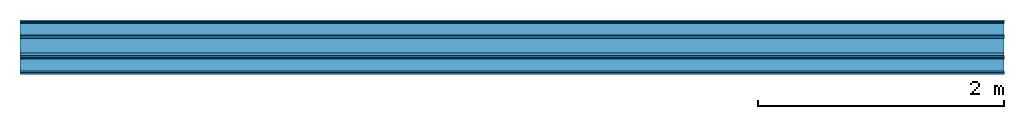
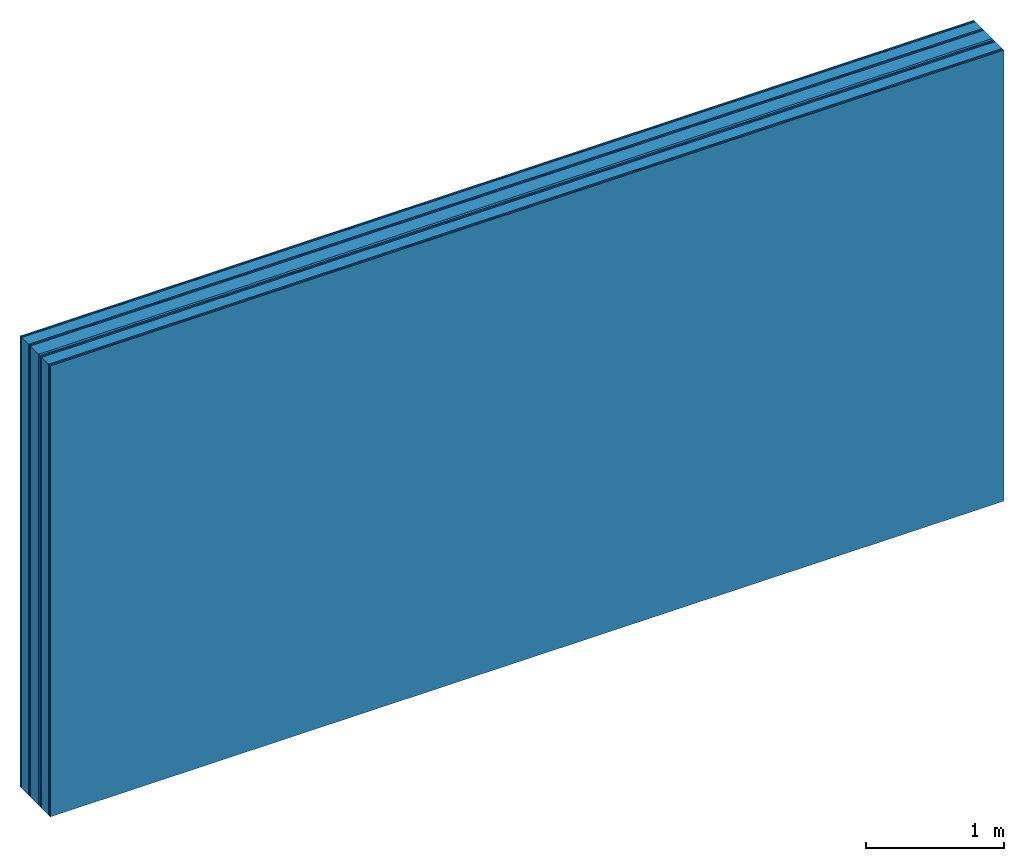
# One storey: 10 plates, 2 members, 1 element without a shape of its own.
"""IFC4 building model written with IfcOpenShell, lengths in metres."""

from ifc_helpers import new_model, si_unit, derived_unit, direction, frame, frame_2d, origin, origin_with_axes, place, context, project, spatial, rectangle, extrude, material, layer, layer_set, type_object, element, aggregate, save


model = new_model("IFC4")

# Units and contexts
plan_context = context("Plan", 3, precision=1e-05, world=origin(), true_north=direction((0.0, 1.0)))
model_context = context("Model", 3, precision=1e-05, world=origin(), true_north=direction((0.0, 1.0)))
ifc_project = project(units=[si_unit("LENGTHUNIT", "METRE"), derived_unit("SOUNDPRESSUREUNIT", [(si_unit("PRESSUREUNIT", "PASCAL", prefix="MICRO"), 0)]), si_unit("ENERGYUNIT", "JOULE", prefix="MEGA"), si_unit("MASSUNIT", "GRAM", prefix="KILO"), derived_unit("THERMALTRANSMITTANCEUNIT", [(si_unit("POWERUNIT", "WATT"), 1), (si_unit("AREAUNIT", "SQUARE_METRE"), -1), (si_unit("THERMODYNAMICTEMPERATUREUNIT", "KELVIN"), -1)]), derived_unit("AREADENSITYUNIT", [(si_unit("MASSUNIT", "GRAM", prefix="KILO"), 1), (si_unit("AREAUNIT", "SQUARE_METRE"), -1)]), derived_unit("USERDEFINED", [(si_unit("ENERGYUNIT", "JOULE", prefix="MEGA"), 1), (si_unit("AREAUNIT", "SQUARE_METRE"), -1)])], contexts=[plan_context, model_context])

# Site, building, storey
site = spatial("IfcSite", under=ifc_project)
building_placement = place(None, origin())
building = spatial("IfcBuilding", under=site, at=building_placement)
storey_placement = place(building_placement, origin())
storey = spatial("IfcBuildingStorey", under=building, at=storey_placement)

# Wall, members, plates
ifc_material_1 = material(Name="joints", Category="04.017")
ifc_layer_1 = layer(ifc_material_1, 0.0, Name="Surface")
ifc_material_2 = material(Name="Rigidur H", Category="03.007")
ifc_layer_2 = layer(ifc_material_2, 0.0125, Name="room side 2nd layer")
ifc_layer_3 = layer(ifc_material_2, 0.0125, Name="room side 1st layer")
ifc_material_3 = material(Name="of the art")
ifc_layer_4 = layer(ifc_material_3, 0.0, Name="Bond")
ifc_layer_5 = layer(None, 0.1, Name="Support")
ifc_layer_6 = layer(ifc_material_3, 0.0, Name="Bond")
ifc_layer_7 = layer(ifc_material_2, 0.0125, Name="outside 1st layer")
ifc_layer_8 = layer(ifc_material_2, 0.0125, Name="outside 2nd layer")
ifc_material_4 = material(Category="10.008")
ifc_layer_9 = layer(ifc_material_4, 0.12, Name="Intermediate insulation")
ifc_material_5 = material(Name="Air")
ifc_layer_10 = layer(ifc_material_5, 0.02, Name="Air gap")
ifc_layer_11 = layer(ifc_material_2, 0.0125, Name="2nd layer")
ifc_layer_12 = layer(ifc_material_2, 0.0125, Name="outside 1st layer")
ifc_layer_13 = layer(ifc_material_3, 0.0, Name="Bond")
ifc_layer_14 = layer(None, 0.1, Name="Support")
ifc_layer_15 = layer(ifc_material_3, 0.0, Name="Bond")
ifc_layer_16 = layer(ifc_material_2, 0.0125, Name="room side 1st layer")
ifc_layer_17 = layer(ifc_material_2, 0.0125, Name="room side 2nd layer")
ifc_layer_18 = layer(ifc_material_1, 0.0, Name="Surface")
ifc_layer_set = layer_set([ifc_layer_1, ifc_layer_2, ifc_layer_3, ifc_layer_4, ifc_layer_5, ifc_layer_6, ifc_layer_7, ifc_layer_8, ifc_layer_9, ifc_layer_10, ifc_layer_11, ifc_layer_12, ifc_layer_13, ifc_layer_14, ifc_layer_15, ifc_layer_16, ifc_layer_17, ifc_layer_18])
wall_type = type_object("IfcWallType", Name="B0325", PredefinedType="NOTDEFINED", material=ifc_layer_set)
wall_placement = place(None, frame((0.0, 0.0, 0.0), z_axis=(0.0, -1.0, 0.0), x_axis=(1.0, 0.0, 0.0)))
wall = element("IfcWall", 1, at=wall_placement, inside=storey, type_object=wall_type, material=ifc_layer_set, Name="Wall #1")
ifc_material_6 = material(Name="OSB")
member_1_placement = place(wall_placement, origin())
member_1 = element("IfcMember", 2, at=member_1_placement, material=ifc_material_6, Name="Support", context=plan_context, shape_type="SweptSolid", body=[
    extrude(rectangle(XDim=1.0, YDim=0.1, at=frame_2d((0.5, 0.05), x_axis=(1.0, 0.0))), frame((0.0, 4.0, 0.025), z_axis=(0.0, -1.0, 0.0), x_axis=(1.0, 0.0, 0.0)), (0.0, 0.0, 1.0), 4.0),
    extrude(rectangle(XDim=1.0, YDim=0.1, at=frame_2d((0.5, 0.05), x_axis=(1.0, 0.0))), frame((1.0, 4.0, 0.025), z_axis=(0.0, -1.0, 0.0), x_axis=(1.0, 0.0, 0.0)), (0.0, 0.0, 1.0), 4.0),
    extrude(rectangle(XDim=1.0, YDim=0.1, at=frame_2d((0.5, 0.05), x_axis=(1.0, 0.0))), frame((2.0, 4.0, 0.025), z_axis=(0.0, -1.0, 0.0), x_axis=(1.0, 0.0, 0.0)), (0.0, 0.0, 1.0), 4.0),
    extrude(rectangle(XDim=1.0, YDim=0.1, at=frame_2d((0.5, 0.05), x_axis=(1.0, 0.0))), frame((3.0, 4.0, 0.025), z_axis=(0.0, -1.0, 0.0), x_axis=(1.0, 0.0, 0.0)), (0.0, 0.0, 1.0), 4.0),
    extrude(rectangle(XDim=1.0, YDim=0.1, at=frame_2d((0.5, 0.05), x_axis=(1.0, 0.0))), frame((4.0, 4.0, 0.025), z_axis=(0.0, -1.0, 0.0), x_axis=(1.0, 0.0, 0.0)), (0.0, 0.0, 1.0), 4.0),
    extrude(rectangle(XDim=1.0, YDim=0.1, at=frame_2d((0.5, 0.05), x_axis=(1.0, 0.0))), frame((5.0, 4.0, 0.025), z_axis=(0.0, -1.0, 0.0), x_axis=(1.0, 0.0, 0.0)), (0.0, 0.0, 1.0), 4.0),
    extrude(rectangle(XDim=1.0, YDim=0.1, at=frame_2d((0.5, 0.05), x_axis=(1.0, 0.0))), frame((6.0, 4.0, 0.025), z_axis=(0.0, -1.0, 0.0), x_axis=(1.0, 0.0, 0.0)), (0.0, 0.0, 1.0), 4.0),
    extrude(rectangle(XDim=1.0, YDim=0.1, at=frame_2d((0.5, 0.05), x_axis=(1.0, 0.0))), frame((7.0, 4.0, 0.025), z_axis=(0.0, -1.0, 0.0), x_axis=(1.0, 0.0, 0.0)), (0.0, 0.0, 1.0), 4.0),
])
member_2_placement = place(wall_placement, origin())
member_2 = element("IfcMember", 3, at=member_2_placement, material=ifc_material_6, Name="Support", context=plan_context, shape_type="SweptSolid", body=[
    extrude(rectangle(XDim=1.0, YDim=0.1, at=frame_2d((0.5, 0.05), x_axis=(1.0, 0.0))), frame((0.0, 4.0, 0.315), z_axis=(0.0, -1.0, 0.0), x_axis=(1.0, 0.0, 0.0)), (0.0, 0.0, 1.0), 4.0),
    extrude(rectangle(XDim=1.0, YDim=0.1, at=frame_2d((0.5, 0.05), x_axis=(1.0, 0.0))), frame((1.0, 4.0, 0.315), z_axis=(0.0, -1.0, 0.0), x_axis=(1.0, 0.0, 0.0)), (0.0, 0.0, 1.0), 4.0),
    extrude(rectangle(XDim=1.0, YDim=0.1, at=frame_2d((0.5, 0.05), x_axis=(1.0, 0.0))), frame((2.0, 4.0, 0.315), z_axis=(0.0, -1.0, 0.0), x_axis=(1.0, 0.0, 0.0)), (0.0, 0.0, 1.0), 4.0),
    extrude(rectangle(XDim=1.0, YDim=0.1, at=frame_2d((0.5, 0.05), x_axis=(1.0, 0.0))), frame((3.0, 4.0, 0.315), z_axis=(0.0, -1.0, 0.0), x_axis=(1.0, 0.0, 0.0)), (0.0, 0.0, 1.0), 4.0),
    extrude(rectangle(XDim=1.0, YDim=0.1, at=frame_2d((0.5, 0.05), x_axis=(1.0, 0.0))), frame((4.0, 4.0, 0.315), z_axis=(0.0, -1.0, 0.0), x_axis=(1.0, 0.0, 0.0)), (0.0, 0.0, 1.0), 4.0),
    extrude(rectangle(XDim=1.0, YDim=0.1, at=frame_2d((0.5, 0.05), x_axis=(1.0, 0.0))), frame((5.0, 4.0, 0.315), z_axis=(0.0, -1.0, 0.0), x_axis=(1.0, 0.0, 0.0)), (0.0, 0.0, 1.0), 4.0),
    extrude(rectangle(XDim=1.0, YDim=0.1, at=frame_2d((0.5, 0.05), x_axis=(1.0, 0.0))), frame((6.0, 4.0, 0.315), z_axis=(0.0, -1.0, 0.0), x_axis=(1.0, 0.0, 0.0)), (0.0, 0.0, 1.0), 4.0),
    extrude(rectangle(XDim=1.0, YDim=0.1, at=frame_2d((0.5, 0.05), x_axis=(1.0, 0.0))), frame((7.0, 4.0, 0.315), z_axis=(0.0, -1.0, 0.0), x_axis=(1.0, 0.0, 0.0)), (0.0, 0.0, 1.0), 4.0),
])
plate_1_placement = place(wall_placement, origin())
plate_1 = element("IfcPlate", 4, at=plate_1_placement, material=ifc_material_2, Name="room side 2nd layer", context=plan_context, shape_type="SweptSolid", body=[
    extrude(rectangle(XDim=8.0, YDim=4.0, at=frame_2d((4.0, 2.0), x_axis=(1.0, 0.0))), origin_with_axes(), (0.0, 0.0, 1.0), 0.0125),
])
plate_2_placement = place(wall_placement, origin())
plate_2 = element("IfcPlate", 5, at=plate_2_placement, material=ifc_material_2, Name="room side 1st layer", context=plan_context, shape_type="SweptSolid", body=[
    extrude(rectangle(XDim=8.0, YDim=4.0, at=frame_2d((4.0, 2.0), x_axis=(1.0, 0.0))), frame((0.0, 0.0, 0.0125), z_axis=(0.0, 0.0, 1.0), x_axis=(1.0, 0.0, 0.0)), (0.0, 0.0, 1.0), 0.0125),
])
plate_3_placement = place(wall_placement, origin())
plate_3 = element("IfcPlate", 6, at=plate_3_placement, material=ifc_material_2, Name="outside 1st layer", context=plan_context, shape_type="SweptSolid", body=[
    extrude(rectangle(XDim=8.0, YDim=4.0, at=frame_2d((4.0, 2.0), x_axis=(1.0, 0.0))), frame((0.0, 0.0, 0.125), z_axis=(0.0, 0.0, 1.0), x_axis=(1.0, 0.0, 0.0)), (0.0, 0.0, 1.0), 0.0125),
])
plate_4_placement = place(wall_placement, origin())
plate_4 = element("IfcPlate", 7, at=plate_4_placement, material=ifc_material_2, Name="outside 2nd layer", context=plan_context, shape_type="SweptSolid", body=[
    extrude(rectangle(XDim=8.0, YDim=4.0, at=frame_2d((4.0, 2.0), x_axis=(1.0, 0.0))), frame((0.0, 0.0, 0.1375), z_axis=(0.0, 0.0, 1.0), x_axis=(1.0, 0.0, 0.0)), (0.0, 0.0, 1.0), 0.0125),
])
plate_5_placement = place(wall_placement, origin())
plate_5 = element("IfcPlate", 8, at=plate_5_placement, material=ifc_material_4, Name="Intermediate insulation", context=plan_context, shape_type="SweptSolid", body=[
    extrude(rectangle(XDim=8.0, YDim=4.0, at=frame_2d((4.0, 2.0), x_axis=(1.0, 0.0))), frame((0.0, 0.0, 0.15), z_axis=(0.0, 0.0, 1.0), x_axis=(1.0, 0.0, 0.0)), (0.0, 0.0, 1.0), 0.12),
])
plate_6_placement = place(wall_placement, origin())
plate_6 = element("IfcPlate", 9, at=plate_6_placement, material=ifc_material_5, Name="Air gap", context=plan_context, shape_type="SweptSolid", body=[
    extrude(rectangle(XDim=8.0, YDim=4.0, at=frame_2d((4.0, 2.0), x_axis=(1.0, 0.0))), frame((0.0, 0.0, 0.27), z_axis=(0.0, 0.0, 1.0), x_axis=(1.0, 0.0, 0.0)), (0.0, 0.0, 1.0), 0.02),
])
plate_7_placement = place(wall_placement, origin())
plate_7 = element("IfcPlate", 10, at=plate_7_placement, material=ifc_material_2, Name="2nd layer", context=plan_context, shape_type="SweptSolid", body=[
    extrude(rectangle(XDim=8.0, YDim=4.0, at=frame_2d((4.0, 2.0), x_axis=(1.0, 0.0))), frame((0.0, 0.0, 0.29), z_axis=(0.0, 0.0, 1.0), x_axis=(1.0, 0.0, 0.0)), (0.0, 0.0, 1.0), 0.0125),
])
plate_8_placement = place(wall_placement, origin())
plate_8 = element("IfcPlate", 11, at=plate_8_placement, material=ifc_material_2, Name="outside 1st layer", context=plan_context, shape_type="SweptSolid", body=[
    extrude(rectangle(XDim=8.0, YDim=4.0, at=frame_2d((4.0, 2.0), x_axis=(1.0, 0.0))), frame((0.0, 0.0, 0.3025), z_axis=(0.0, 0.0, 1.0), x_axis=(1.0, 0.0, 0.0)), (0.0, 0.0, 1.0), 0.0125),
])
plate_9_placement = place(wall_placement, origin())
plate_9 = element("IfcPlate", 12, at=plate_9_placement, material=ifc_material_2, Name="room side 1st layer", context=plan_context, shape_type="SweptSolid", body=[
    extrude(rectangle(XDim=8.0, YDim=4.0, at=frame_2d((4.0, 2.0), x_axis=(1.0, 0.0))), frame((0.0, 0.0, 0.415), z_axis=(0.0, 0.0, 1.0), x_axis=(1.0, 0.0, 0.0)), (0.0, 0.0, 1.0), 0.0125),
])
plate_10_placement = place(wall_placement, origin())
plate_10 = element("IfcPlate", 13, at=plate_10_placement, material=ifc_material_2, Name="room side 2nd layer", context=plan_context, shape_type="SweptSolid", body=[
    extrude(rectangle(XDim=8.0, YDim=4.0, at=frame_2d((4.0, 2.0), x_axis=(1.0, 0.0))), frame((0.0, 0.0, 0.4275), z_axis=(0.0, 0.0, 1.0), x_axis=(1.0, 0.0, 0.0)), (0.0, 0.0, 1.0), 0.0125),
])
aggregate(wall, [plate_1, plate_2, member_1, plate_3, plate_4, plate_5, plate_6, plate_7, plate_8, member_2, plate_9, plate_10])

save(model, "model.ifc")
